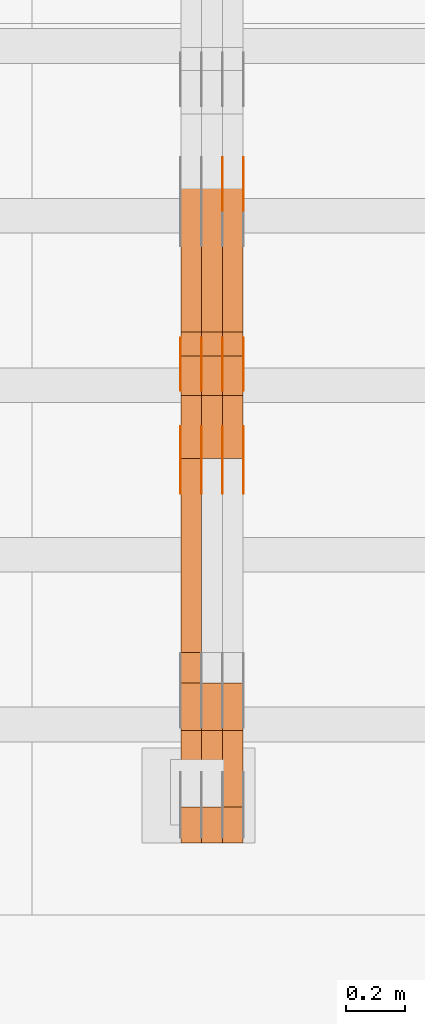
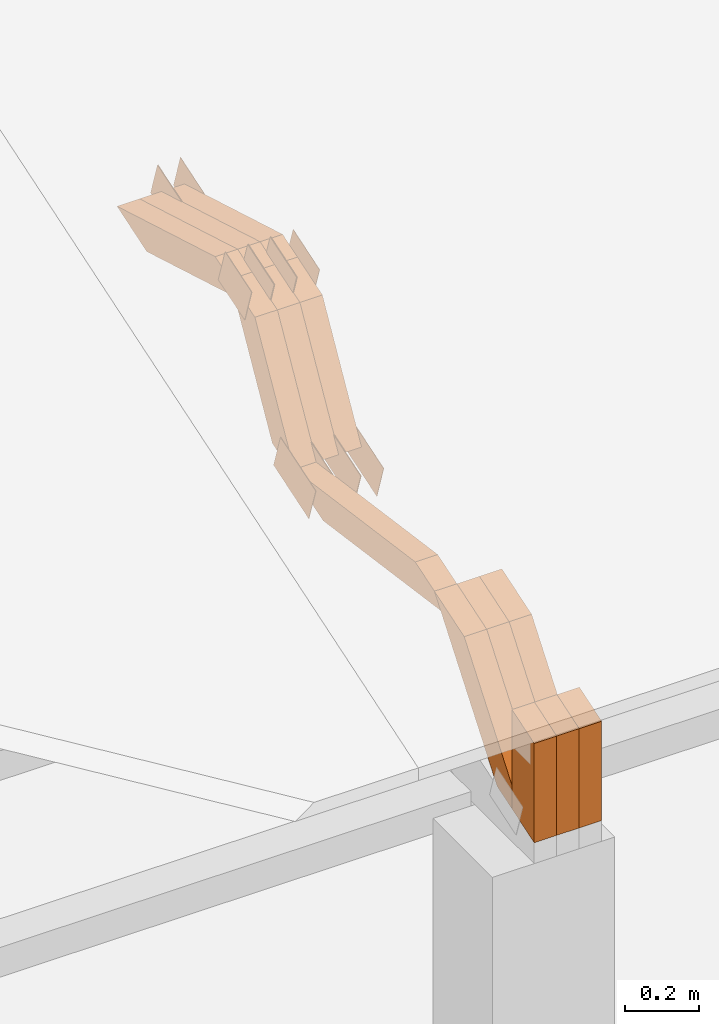
# One storey, part 112 of 385: 28 proxies.
"""IFC2X3 building model written with IfcOpenShell, lengths in millimetres."""

import ifcopenshell
import ifcopenshell.guid

model = None  # the IFC model being written
_history = None  # IfcOwnerHistory: only IFC2X3 demands one
_inside = {}  # id of a spatial element -> (the spatial element, [elements in it])
_under = {}  # id of a project, library or spatial element -> (it, [spatial elements below it])
_declared = {}  # id of a project -> (the project, [libraries it declares])
_typed = {}  # id of a type object -> (the type object, [elements of that type])
_made_of = {}  # id of a material, layer set ... -> (it, [elements and type objects made of it])


def new_model(schema):
    """Start an empty IFC model of exactly this schema.

    Asked for "IFC4X3", IfcOpenShell would pick the latest addendum, in which some entities
    have other attributes; the version numbers below select the first issue.
    IFC2X3 requires an IfcOwnerHistory on every rooted entity: one is made here for all.
    """
    global model, _history
    if schema == "IFC4X3":
        model = ifcopenshell.file(schema_version=(4, 3, 0, 0))
    else:
        model = ifcopenshell.file(schema=schema)
    _inside.clear()
    _under.clear()
    _declared.clear()
    _typed.clear()
    _made_of.clear()
    _history = None
    if model.schema == "IFC2X3":
        org = make("IfcOrganization", Name="unknown")
        user = make(
            "IfcPersonAndOrganization",
            ThePerson=make("IfcPerson", FamilyName="unknown"),
            TheOrganization=org,
        )
        app = make(
            "IfcApplication",
            ApplicationDeveloper=org,
            Version="unknown",
            ApplicationFullName="unknown",
            ApplicationIdentifier="unknown",
        )
        _history = make(
            "IfcOwnerHistory",
            OwningUser=user,
            OwningApplication=app,
            ChangeAction="ADDED",
            CreationDate=0,
        )
    return model


def make(cls, **values):
    """One entity of the class cls with the attributes given. An attribute that is None is left unset."""
    return model.create_entity(
        cls, **{name: value for name, value in values.items() if value is not None}
    )


def entity(cls, *values):
    """Any entity or typed value of the class cls, its attributes in the order of the schema. None: left unset."""
    e = model.create_entity(cls)
    for i, value in enumerate(values):
        if value is not None:
            e[i] = value
    return e


def rooted(cls, **values):
    """An entity with a GlobalId (a new one), such as an element, a storey or a relation."""
    return make(cls, GlobalId=ifcopenshell.guid.new(), OwnerHistory=_history, **values)


def si_unit(unit_type, name, prefix=None):
    """IfcSIUnit, for example si_unit("LENGTHUNIT", "METRE", prefix="MILLI")."""
    return make("IfcSIUnit", UnitType=unit_type, Prefix=prefix, Name=name)


def converted_unit(unit_type, name, factor, base, dimensions=None, offset=None):
    """IfcConversionBasedUnit, such as the inch: factor (a typed value) times the base unit."""
    return make(
        "IfcConversionBasedUnit"
        if offset is None
        else "IfcConversionBasedUnitWithOffset",
        ConversionOffset=offset,
        Dimensions=None
        if dimensions is None
        else entity("IfcDimensionalExponents", *dimensions),
        UnitType=unit_type,
        Name=name,
        ConversionFactor=make(
            "IfcMeasureWithUnit", ValueComponent=factor, UnitComponent=base
        ),
    )


def derived_unit(unit_type, elements):
    """IfcDerivedUnit: a product of units, each with its exponent."""
    return make(
        "IfcDerivedUnit",
        Elements=[
            make("IfcDerivedUnitElement", Unit=unit, Exponent=power)
            for unit, power in elements
        ],
        UnitType=unit_type,
    )


def assignment(units):
    """IfcUnitAssignment: the units of a project."""
    return None if units is None else make("IfcUnitAssignment", Units=units)


def point(xyz):
    """IfcCartesianPoint."""
    return None if xyz is None else make("IfcCartesianPoint", Coordinates=xyz)


def direction(xyz):
    """IfcDirection."""
    return None if xyz is None else make("IfcDirection", DirectionRatios=xyz)


def frame(location, z_axis=None, x_axis=None):
    """IfcAxis2Placement3D, a coordinate frame: its origin and axes. An axis left out is left unset."""
    return make(
        "IfcAxis2Placement3D",
        Location=point(location),
        Axis=direction(z_axis),
        RefDirection=direction(x_axis),
    )


def origin():
    """The frame at (0, 0, 0) with its axes left unset."""
    return frame((0.0, 0.0, 0.0))


def place(relative_to, where):
    """IfcLocalPlacement: puts the frame where relative to a parent placement (None: the world)."""
    return make(
        "IfcLocalPlacement", PlacementRelTo=relative_to, RelativePlacement=where
    )


def context(
    kind, dimensions, precision=None, world=None, true_north=None, identifier=None
):
    """IfcGeometricRepresentationContext, for example the 3D "Model" context."""
    return make(
        "IfcGeometricRepresentationContext",
        ContextIdentifier=identifier,
        ContextType=kind,
        CoordinateSpaceDimension=dimensions,
        Precision=precision,
        WorldCoordinateSystem=world,
        TrueNorth=true_north,
    )


def subcontext(parent, identifier, kind, view, scale=None):
    """IfcGeometricRepresentationSubContext, for example "Body" below "Model"."""
    return make(
        "IfcGeometricRepresentationSubContext",
        ContextIdentifier=identifier,
        ContextType=kind,
        ParentContext=parent,
        TargetScale=scale,
        TargetView=view,
    )


def project(units=None, contexts=None):
    """IfcProject with its units and contexts."""
    return rooted(
        "IfcProject",
        Name="project",
        RepresentationContexts=contexts,
        UnitsInContext=assignment(units),
    )


def spatial(cls, under=None, at=None, **own):
    """A site, building, storey or space (cls), placed at a placement, below another one or the project."""
    s = rooted(cls, ObjectPlacement=at, **own)
    if under is not None:
        _under.setdefault(under.id(), (under, []))[1].append(s)
    return s


def polyline(points):
    """IfcPolyline through the points."""
    return make("IfcPolyline", Points=[point(p) for p in points])


def outline(outer, holes=None, kind="AREA"):
    """IfcArbitraryClosedProfileDef: a profile drawn as a closed curve; with holes, ...WithVoids."""
    if holes is None:
        return make("IfcArbitraryClosedProfileDef", ProfileType=kind, OuterCurve=outer)
    return make(
        "IfcArbitraryProfileDefWithVoids",
        ProfileType=kind,
        OuterCurve=outer,
        InnerCurves=holes,
    )


def extrude(swept, where, along, depth):
    """IfcExtrudedAreaSolid: the profile swept, set in the frame where, extruded along a direction by depth."""
    return make(
        "IfcExtrudedAreaSolid",
        SweptArea=swept,
        Position=where,
        ExtrudedDirection=direction(along),
        Depth=depth,
    )


def shape(context_of_items, identifier, shape_type, items):
    """IfcShapeRepresentation: the items that make up one representation, for example the "Body"."""
    return make(
        "IfcShapeRepresentation",
        ContextOfItems=context_of_items,
        RepresentationIdentifier=identifier,
        RepresentationType=shape_type,
        Items=items,
    )


def source(mapping_origin, context_of_items, identifier, shape_type, items):
    """IfcRepresentationMap: a shape defined once, which mapped items show again and again."""
    return make(
        "IfcRepresentationMap",
        MappingOrigin=mapping_origin,
        MappedRepresentation=shape(context_of_items, identifier, shape_type, items),
    )


def transform(
    local_origin,
    x_axis=None,
    y_axis=None,
    z_axis=None,
    scale=None,
    scale2=None,
    scale3=None,
    uniform=True,
):
    """IfcCartesianTransformationOperator3D, or its non-uniform kind. x_axis, y_axis, z_axis: its Axis1, 2, 3."""
    if uniform:
        return make(
            "IfcCartesianTransformationOperator3D",
            Axis1=direction(x_axis),
            Axis2=direction(y_axis),
            LocalOrigin=point(local_origin),
            Scale=scale,
            Axis3=direction(z_axis),
        )
    return make(
        "IfcCartesianTransformationOperator3DnonUniform",
        Axis1=direction(x_axis),
        Axis2=direction(y_axis),
        LocalOrigin=point(local_origin),
        Scale=scale,
        Axis3=direction(z_axis),
        Scale2=scale2,
        Scale3=scale3,
    )


def mapped(mapping_source, mapping_target):
    """IfcMappedItem: shows the shape of a source again, moved by a transform."""
    return make(
        "IfcMappedItem", MappingSource=mapping_source, MappingTarget=mapping_target
    )


def material(Name=None, Category=None):
    """IfcMaterial."""
    return make("IfcMaterial", Name=Name, Category=Category)


def made_of(thing, what):
    """Note that an element or type object is made of a material, layer set ...; save() writes the relation."""
    if what is not None:
        _made_of.setdefault(what.id(), (what, []))[1].append(thing)
    return thing


def type_object(cls, material=None, **own):
    """A type object (cls), such as IfcWallType, which elements share."""
    return made_of(rooted(cls, **own), material)


def type_shapes(of_type, sources):
    """Give a type object the sources (RepresentationMaps) that its elements show as mapped items."""
    of_type.RepresentationMaps = sources


def element(
    cls,
    number,
    at=None,
    inside=None,
    cuts=None,
    type_object=None,
    material=None,
    context=None,
    identifier="Body",
    shape_type=None,
    held_by="IfcProductDefinitionShape",
    body=None,
    shapes=None,
    **own,
):
    """One element of the class cls, such as IfcWall. Its Tag is "e" and its number.

    at: its placement. inside: the storey or other place that contains it. cuts: it is an
    opening in that element (IfcRelVoidsElement). A single representation is given by context,
    identifier, shape_type and body (its items); several are given by shapes. held_by: the class
    of the entity that holds the representations. save() writes the other relations.
    """
    e = rooted(cls, Tag="e%d" % number, ObjectPlacement=at, **own)
    if body is not None:
        shapes = [shape(context, identifier, shape_type, body)]
    if shapes is not None:
        e.Representation = make(held_by, Representations=shapes)
    if inside is not None:
        _inside.setdefault(inside.id(), (inside, []))[1].append(e)
    if cuts is not None:
        rooted(
            "IfcRelVoidsElement", RelatingBuildingElement=cuts, RelatedOpeningElement=e
        )
    if type_object is not None:
        _typed.setdefault(type_object.id(), (type_object, []))[1].append(e)
    return made_of(e, material)


def aggregate(whole, parts):
    """IfcRelAggregates: a whole, such as a stair, and the parts it consists of."""
    return rooted("IfcRelAggregates", RelatingObject=whole, RelatedObjects=parts)


def save(model, path):
    """Write the relations noted so far, then the file.

    IfcRelAggregates (storeys below a building ...), IfcRelContainedInSpatialStructure (elements
    in a storey), IfcRelDefinesByType, IfcRelAssociatesMaterial and IfcRelDeclares: one each for
    every whole, place, type object, material and project.
    """
    for whole, parts in _under.values():
        aggregate(whole, parts)
    for where, things in _inside.values():
        rooted(
            "IfcRelContainedInSpatialStructure",
            RelatedElements=things,
            RelatingStructure=where,
        )
    for kind, things in _typed.values():
        rooted("IfcRelDefinesByType", RelatedObjects=things, RelatingType=kind)
    for what, things in _made_of.values():
        rooted("IfcRelAssociatesMaterial", RelatedObjects=things, RelatingMaterial=what)
    for by, libraries in _declared.values():
        rooted("IfcRelDeclares", RelatingContext=by, RelatedDefinitions=libraries)
    model.write(path)


model = new_model("IFC2X3")

# Units and contexts
model_context = context("Model", 3, precision=0.01, world=origin(), true_north=direction((6.12303176911189e-17, 1.0)))
body_context = subcontext(model_context, "Body", "Model", "MODEL_VIEW")
ifc_project = project(units=[si_unit("LENGTHUNIT", "METRE", prefix="MILLI"), si_unit("AREAUNIT", "SQUARE_METRE"), si_unit("VOLUMEUNIT", "CUBIC_METRE"), converted_unit("PLANEANGLEUNIT", "DEGREE", entity("IfcRatioMeasure", 0.0174532925199433), si_unit("PLANEANGLEUNIT", "RADIAN"), dimensions=[0, 0, 0, 0, 0, 0, 0]), si_unit("MASSUNIT", "GRAM", prefix="KILO"), derived_unit("MASSDENSITYUNIT", [(si_unit("MASSUNIT", "GRAM", prefix="KILO"), 1), (si_unit("LENGTHUNIT", "METRE"), -3)]), si_unit("TIMEUNIT", "SECOND"), si_unit("FREQUENCYUNIT", "HERTZ"), si_unit("THERMODYNAMICTEMPERATUREUNIT", "DEGREE_CELSIUS"), derived_unit("THERMALTRANSMITTANCEUNIT", [(si_unit("MASSUNIT", "GRAM", prefix="KILO"), 1), (si_unit("THERMODYNAMICTEMPERATUREUNIT", "KELVIN"), -1), (si_unit("TIMEUNIT", "SECOND"), -3)]), derived_unit("VOLUMETRICFLOWRATEUNIT", [(si_unit("LENGTHUNIT", "METRE"), 3), (si_unit("TIMEUNIT", "SECOND"), -1)]), si_unit("ELECTRICCURRENTUNIT", "AMPERE"), si_unit("ELECTRICVOLTAGEUNIT", "VOLT"), si_unit("POWERUNIT", "WATT"), si_unit("FORCEUNIT", "NEWTON", prefix="KILO"), si_unit("ILLUMINANCEUNIT", "LUX"), si_unit("LUMINOUSFLUXUNIT", "LUMEN"), si_unit("LUMINOUSINTENSITYUNIT", "CANDELA"), derived_unit("USERDEFINED", [(si_unit("MASSUNIT", "GRAM", prefix="KILO"), -1), (si_unit("LENGTHUNIT", "METRE"), -2), (si_unit("TIMEUNIT", "SECOND"), 3), (si_unit("LUMINOUSFLUXUNIT", "LUMEN"), 1)]), derived_unit("LINEARVELOCITYUNIT", [(si_unit("LENGTHUNIT", "METRE"), 1), (si_unit("TIMEUNIT", "SECOND"), -1)]), si_unit("PRESSUREUNIT", "PASCAL"), derived_unit("USERDEFINED", [(si_unit("LENGTHUNIT", "METRE"), -2), (si_unit("MASSUNIT", "GRAM", prefix="KILO"), 1), (si_unit("TIMEUNIT", "SECOND"), -2)])], contexts=[model_context])

# Site, building, storey
site_placement = place(None, origin())
site = spatial("IfcSite", under=ifc_project, at=site_placement, CompositionType="ELEMENT")
building_placement = place(site_placement, origin())
building = spatial("IfcBuilding", under=site, at=building_placement, CompositionType="ELEMENT")
storey_placement = place(building_placement, origin())
storey = spatial("IfcBuildingStorey", under=building, at=storey_placement, Name="Default", CompositionType="ELEMENT", Elevation=0.0)

# Proxies
ifc_material_1 = material(Name="IfcSurfaceStyle #270822")
building_element_proxy_type_1 = type_object("IfcBuildingElementProxyType", PredefinedType="NOTDEFINED", material=ifc_material_1)
shared_shape_1 = source(origin(), body_context, "Body", "SweptSolid", [
    extrude(outline(polyline([(-99.9998204243802, -60.000067376167), (99.9998338462265, -60.000067376167), (99.9998204243802, 60.000067376167), (-99.9998338462265, 60.000067376167), (-99.9998204243802, -60.000067376167)])), frame((100.000602015329, 60.0001864986889, 0.0), z_axis=(0.0, 0.0, 1.0), x_axis=(-1.0, 0.0, 0.0)), (0.0, 0.0, 1.0), 1.3),
])
type_shapes(building_element_proxy_type_1, [shared_shape_1])
proxy_1_placement = place(building_placement, frame((21386.3, 4114.85465165112, 513.097031388771), z_axis=(-1.0, 0.0, 0.0), x_axis=(0.0, 0.951056516295124, 0.309016994375039)))
element("IfcBuildingElementProxy", 1, at=proxy_1_placement, inside=storey, type_object=building_element_proxy_type_1, material=ifc_material_1, context=body_context, shape_type="MappedRepresentation", body=[
    mapped(shared_shape_1, transform((0.0, 0.0, 0.0), scale=1.0)),
])
ifc_material_2 = material(Name="IfcSurfaceStyle #270765")
building_element_proxy_type_2 = type_object("IfcBuildingElementProxyType", PredefinedType="NOTDEFINED", material=ifc_material_2)
shared_shape_2 = source(origin(), body_context, "Body", "SweptSolid", [
    extrude(outline(polyline([(-99.9998204243802, -60.000067376167), (99.9998338462265, -60.000067376167), (99.9998204243802, 60.000067376167), (-99.9998338462265, 60.000067376167), (-99.9998204243802, -60.000067376167)])), frame((100.000602015329, 60.0001864986889, 0.0), z_axis=(0.0, 0.0, 1.0), x_axis=(-1.0, 0.0, 0.0)), (0.0, 0.0, 1.0), 1.3),
])
type_shapes(building_element_proxy_type_2, [shared_shape_2])
proxy_2_placement = place(building_placement, frame((21315.0, 4114.85465165112, 513.097031388771), z_axis=(-1.0, 0.0, 0.0), x_axis=(0.0, 0.951056516295124, 0.309016994375039)))
element("IfcBuildingElementProxy", 2, at=proxy_2_placement, inside=storey, type_object=building_element_proxy_type_2, material=ifc_material_2, context=body_context, shape_type="MappedRepresentation", body=[
    mapped(shared_shape_2, transform((0.0, 0.0, 0.0), scale=1.0)),
])
ifc_material_3 = material(Name="IfcSurfaceStyle #270708")
building_element_proxy_type_3 = type_object("IfcBuildingElementProxyType", PredefinedType="NOTDEFINED", material=ifc_material_3)
shared_shape_3 = source(origin(), body_context, "Body", "SweptSolid", [
    extrude(outline(polyline([(-99.9998204243802, -60.000067376167), (99.9998338462265, -60.000067376167), (99.9998204243802, 60.000067376167), (-99.9998338462265, 60.000067376167), (-99.9998204243802, -60.000067376167)])), frame((100.000602015329, 60.0001864986889, 0.0), z_axis=(0.0, 0.0, 1.0), x_axis=(-1.0, 0.0, 0.0)), (0.0, 0.0, 1.0), 1.3),
])
type_shapes(building_element_proxy_type_3, [shared_shape_3])
proxy_3_placement = place(building_placement, frame((21316.3, 4114.85465165112, 513.097031388771), z_axis=(-1.0, 0.0, 0.0), x_axis=(0.0, 0.951056516295124, 0.309016994375039)))
element("IfcBuildingElementProxy", 3, at=proxy_3_placement, inside=storey, type_object=building_element_proxy_type_3, material=ifc_material_3, context=body_context, shape_type="MappedRepresentation", body=[
    mapped(shared_shape_3, transform((0.0, 0.0, 0.0), scale=1.0)),
])
ifc_material_4 = material(Name="IfcSurfaceStyle #270651")
building_element_proxy_type_4 = type_object("IfcBuildingElementProxyType", PredefinedType="NOTDEFINED", material=ifc_material_4)
shared_shape_4 = source(origin(), body_context, "Body", "SweptSolid", [
    extrude(outline(polyline([(-99.9998204243802, -60.000067376167), (99.9998338462265, -60.000067376167), (99.9998204243802, 60.000067376167), (-99.9998338462265, 60.000067376167), (-99.9998204243802, -60.000067376167)])), frame((100.000602015329, 60.0001864986889, 0.0), z_axis=(0.0, 0.0, 1.0), x_axis=(-1.0, 0.0, 0.0)), (0.0, 0.0, 1.0), 1.29999999999998),
])
type_shapes(building_element_proxy_type_4, [shared_shape_4])
proxy_4_placement = place(building_placement, frame((21245.0, 4114.85465165112, 513.097031388771), z_axis=(-1.0, 0.0, 0.0), x_axis=(0.0, 0.951056516295124, 0.309016994375039)))
element("IfcBuildingElementProxy", 4, at=proxy_4_placement, inside=storey, type_object=building_element_proxy_type_4, material=ifc_material_4, context=body_context, shape_type="MappedRepresentation", body=[
    mapped(shared_shape_4, transform((0.0, 0.0, 0.0), scale=1.0)),
])
ifc_material_5 = material(Name="IfcSurfaceStyle #270594")
building_element_proxy_type_5 = type_object("IfcBuildingElementProxyType", PredefinedType="NOTDEFINED", material=ifc_material_5)
shared_shape_5 = source(origin(), body_context, "Body", "SweptSolid", [
    extrude(outline(polyline([(-99.9998204243802, -60.000067376167), (99.9998338462265, -60.000067376167), (99.9998204243802, 60.000067376167), (-99.9998338462265, 60.000067376167), (-99.9998204243802, -60.000067376167)])), frame((100.000602015329, 60.0001864986889, 0.0), z_axis=(0.0, 0.0, 1.0), x_axis=(-1.0, 0.0, 0.0)), (0.0, 0.0, 1.0), 1.29999999999998),
])
type_shapes(building_element_proxy_type_5, [shared_shape_5])
proxy_5_placement = place(building_placement, frame((21246.3, 4114.85465165112, 513.097031388771), z_axis=(-1.0, 0.0, 0.0), x_axis=(0.0, 0.951056516295124, 0.309016994375039)))
element("IfcBuildingElementProxy", 5, at=proxy_5_placement, inside=storey, type_object=building_element_proxy_type_5, material=ifc_material_5, context=body_context, shape_type="MappedRepresentation", body=[
    mapped(shared_shape_5, transform((0.0, 0.0, 0.0), scale=1.0)),
])
ifc_material_6 = material(Name="IfcSurfaceStyle #270537")
building_element_proxy_type_6 = type_object("IfcBuildingElementProxyType", PredefinedType="NOTDEFINED", material=ifc_material_6)
shared_shape_6 = source(origin(), body_context, "Body", "SweptSolid", [
    extrude(outline(polyline([(-99.9998204243802, -60.000067376167), (99.9998338462265, -60.000067376167), (99.9998204243802, 60.000067376167), (-99.9998338462265, 60.000067376167), (-99.9998204243802, -60.000067376167)])), frame((100.000602015329, 60.0001864986889, 0.0), z_axis=(0.0, 0.0, 1.0), x_axis=(-1.0, 0.0, 0.0)), (0.0, 0.0, 1.0), 1.29999999999999),
])
type_shapes(building_element_proxy_type_6, [shared_shape_6])
proxy_6_placement = place(building_placement, frame((21175.0, 4114.85465165112, 513.097031388771), z_axis=(-1.0, 0.0, 0.0), x_axis=(0.0, 0.951056516295124, 0.309016994375039)))
element("IfcBuildingElementProxy", 6, at=proxy_6_placement, inside=storey, type_object=building_element_proxy_type_6, material=ifc_material_6, context=body_context, shape_type="MappedRepresentation", body=[
    mapped(shared_shape_6, transform((0.0, 0.0, 0.0), scale=1.0)),
])
ifc_material_7 = material(Name="IfcSurfaceStyle #270480")
building_element_proxy_type_7 = type_object("IfcBuildingElementProxyType", PredefinedType="NOTDEFINED", material=ifc_material_7)
shared_shape_7 = source(origin(), body_context, "Body", "SweptSolid", [
    extrude(outline(polyline([(-74.9998707133927, -60.0000596852269), (74.9998841352353, -60.0000596852269), (74.999861282944, 60.0000596852269), (-74.9998747047866, 60.0000596852269), (-74.9998707133927, -60.0000596852269)])), frame((74.9998841352353, 60.0000596852269, 0.0), z_axis=(0.0, 0.0, 1.0), x_axis=(-1.0, 0.0, 0.0)), (0.0, 0.0, 1.0), 1.3),
])
type_shapes(building_element_proxy_type_7, [shared_shape_7])
proxy_7_placement = place(building_placement, frame((21386.3, 5067.4882362875, 826.131473120182), z_axis=(-1.0, 0.0, 0.0), x_axis=(0.0, 0.951056516295124, 0.309016994375039)))
element("IfcBuildingElementProxy", 7, at=proxy_7_placement, inside=storey, type_object=building_element_proxy_type_7, material=ifc_material_7, context=body_context, shape_type="MappedRepresentation", body=[
    mapped(shared_shape_7, transform((0.0, 0.0, 0.0), scale=1.0)),
])
ifc_material_8 = material(Name="IfcSurfaceStyle #270423")
building_element_proxy_type_8 = type_object("IfcBuildingElementProxyType", PredefinedType="NOTDEFINED", material=ifc_material_8)
shared_shape_8 = source(origin(), body_context, "Body", "SweptSolid", [
    extrude(outline(polyline([(-74.9998707133927, -60.0000596852269), (74.9998841352353, -60.0000596852269), (74.999861282944, 60.0000596852269), (-74.9998747047866, 60.0000596852269), (-74.9998707133927, -60.0000596852269)])), frame((74.9998841352353, 60.0000596852269, 0.0), z_axis=(0.0, 0.0, 1.0), x_axis=(-1.0, 0.0, 0.0)), (0.0, 0.0, 1.0), 1.3),
])
type_shapes(building_element_proxy_type_8, [shared_shape_8])
proxy_8_placement = place(building_placement, frame((21315.0, 5067.4882362875, 826.131473120182), z_axis=(-1.0, 0.0, 0.0), x_axis=(0.0, 0.951056516295124, 0.309016994375039)))
element("IfcBuildingElementProxy", 8, at=proxy_8_placement, inside=storey, type_object=building_element_proxy_type_8, material=ifc_material_8, context=body_context, shape_type="MappedRepresentation", body=[
    mapped(shared_shape_8, transform((0.0, 0.0, 0.0), scale=1.0)),
])
ifc_material_9 = material(Name="IfcSurfaceStyle #270366")
building_element_proxy_type_9 = type_object("IfcBuildingElementProxyType", PredefinedType="NOTDEFINED", material=ifc_material_9)
shared_shape_9 = source(origin(), body_context, "Body", "SweptSolid", [
    extrude(outline(polyline([(-74.9998707133927, -60.0000596852269), (74.9998841352353, -60.0000596852269), (74.999861282944, 60.0000596852269), (-74.9998747047866, 60.0000596852269), (-74.9998707133927, -60.0000596852269)])), frame((74.9998841352353, 60.0000596852269, 0.0), z_axis=(0.0, 0.0, 1.0), x_axis=(-1.0, 0.0, 0.0)), (0.0, 0.0, 1.0), 1.3),
])
type_shapes(building_element_proxy_type_9, [shared_shape_9])
proxy_9_placement = place(building_placement, frame((21316.3, 5067.4882362875, 826.131473120182), z_axis=(-1.0, 0.0, 0.0), x_axis=(0.0, 0.951056516295124, 0.309016994375039)))
element("IfcBuildingElementProxy", 9, at=proxy_9_placement, inside=storey, type_object=building_element_proxy_type_9, material=ifc_material_9, context=body_context, shape_type="MappedRepresentation", body=[
    mapped(shared_shape_9, transform((0.0, 0.0, 0.0), scale=1.0)),
])
ifc_material_10 = material(Name="IfcSurfaceStyle #263640")
building_element_proxy_type_10 = type_object("IfcBuildingElementProxyType", PredefinedType="NOTDEFINED", material=ifc_material_10)
shared_shape_10 = source(origin(), body_context, "Body", "SweptSolid", [
    extrude(outline(polyline([(-74.999865998172, -60.0000306612919), (74.999869989555, -60.0000306612919), (74.999865998172, 60.0000306612919), (-74.999869989555, 60.0000306612919), (-74.999865998172, -60.0000306612919)])), frame((75.0006726017528, 60.0001996460842, 0.0), z_axis=(0.0, 0.0, 1.0), x_axis=(-1.0, 0.0, 0.0)), (0.0, 0.0, 1.0), 1.3),
])
type_shapes(building_element_proxy_type_10, [shared_shape_10])
proxy_10_placement = place(building_placement, frame((21386.3, 4460.38978242656, 957.314497110567), z_axis=(-1.0, 0.0, 0.0), x_axis=(0.0, 0.951056516295154, 0.309016994374948)))
element("IfcBuildingElementProxy", 10, at=proxy_10_placement, inside=storey, type_object=building_element_proxy_type_10, material=ifc_material_10, context=body_context, shape_type="MappedRepresentation", body=[
    mapped(shared_shape_10, transform((0.0, 0.0, 0.0), scale=1.0)),
])
ifc_material_11 = material(Name="IfcSurfaceStyle #263583")
building_element_proxy_type_11 = type_object("IfcBuildingElementProxyType", PredefinedType="NOTDEFINED", material=ifc_material_11)
shared_shape_11 = source(origin(), body_context, "Body", "SweptSolid", [
    extrude(outline(polyline([(-74.999865998172, -60.0000306612919), (74.999869989555, -60.0000306612919), (74.999865998172, 60.0000306612919), (-74.999869989555, 60.0000306612919), (-74.999865998172, -60.0000306612919)])), frame((75.0006726017528, 60.0001996460842, 0.0), z_axis=(0.0, 0.0, 1.0), x_axis=(-1.0, 0.0, 0.0)), (0.0, 0.0, 1.0), 1.3),
])
type_shapes(building_element_proxy_type_11, [shared_shape_11])
proxy_11_placement = place(building_placement, frame((21315.0, 4460.38978242656, 957.314497110567), z_axis=(-1.0, 0.0, 0.0), x_axis=(0.0, 0.951056516295154, 0.309016994374948)))
element("IfcBuildingElementProxy", 11, at=proxy_11_placement, inside=storey, type_object=building_element_proxy_type_11, material=ifc_material_11, context=body_context, shape_type="MappedRepresentation", body=[
    mapped(shared_shape_11, transform((0.0, 0.0, 0.0), scale=1.0)),
])
ifc_material_12 = material(Name="IfcSurfaceStyle #263526")
building_element_proxy_type_12 = type_object("IfcBuildingElementProxyType", PredefinedType="NOTDEFINED", material=ifc_material_12)
shared_shape_12 = source(origin(), body_context, "Body", "SweptSolid", [
    extrude(outline(polyline([(-74.999865998172, -60.0000306612919), (74.999869989555, -60.0000306612919), (74.999865998172, 60.0000306612919), (-74.999869989555, 60.0000306612919), (-74.999865998172, -60.0000306612919)])), frame((75.0006726017528, 60.0001996460842, 0.0), z_axis=(0.0, 0.0, 1.0), x_axis=(-1.0, 0.0, 0.0)), (0.0, 0.0, 1.0), 1.3),
])
type_shapes(building_element_proxy_type_12, [shared_shape_12])
proxy_12_placement = place(building_placement, frame((21316.3, 4460.38978242656, 957.314497110567), z_axis=(-1.0, 0.0, 0.0), x_axis=(0.0, 0.951056516295154, 0.309016994374948)))
element("IfcBuildingElementProxy", 12, at=proxy_12_placement, inside=storey, type_object=building_element_proxy_type_12, material=ifc_material_12, context=body_context, shape_type="MappedRepresentation", body=[
    mapped(shared_shape_12, transform((0.0, 0.0, 0.0), scale=1.0)),
])
ifc_material_13 = material(Name="IfcSurfaceStyle #263469")
building_element_proxy_type_13 = type_object("IfcBuildingElementProxyType", PredefinedType="NOTDEFINED", material=ifc_material_13)
shared_shape_13 = source(origin(), body_context, "Body", "SweptSolid", [
    extrude(outline(polyline([(-74.999865998172, -60.0000306612919), (74.999869989555, -60.0000306612919), (74.999865998172, 60.0000306612919), (-74.999869989555, 60.0000306612919), (-74.999865998172, -60.0000306612919)])), frame((75.0006726017528, 60.0001996460842, 0.0), z_axis=(0.0, 0.0, 1.0), x_axis=(-1.0, 0.0, 0.0)), (0.0, 0.0, 1.0), 1.29999999999999),
])
type_shapes(building_element_proxy_type_13, [shared_shape_13])
proxy_13_placement = place(building_placement, frame((21245.0, 4460.38978242656, 957.314497110567), z_axis=(-1.0, 0.0, 0.0), x_axis=(0.0, 0.951056516295154, 0.309016994374948)))
element("IfcBuildingElementProxy", 13, at=proxy_13_placement, inside=storey, type_object=building_element_proxy_type_13, material=ifc_material_13, context=body_context, shape_type="MappedRepresentation", body=[
    mapped(shared_shape_13, transform((0.0, 0.0, 0.0), scale=1.0)),
])
ifc_material_14 = material(Name="IfcSurfaceStyle #263412")
building_element_proxy_type_14 = type_object("IfcBuildingElementProxyType", PredefinedType="NOTDEFINED", material=ifc_material_14)
shared_shape_14 = source(origin(), body_context, "Body", "SweptSolid", [
    extrude(outline(polyline([(-74.999865998172, -60.0000306612919), (74.999869989555, -60.0000306612919), (74.999865998172, 60.0000306612919), (-74.999869989555, 60.0000306612919), (-74.999865998172, -60.0000306612919)])), frame((75.0006726017528, 60.0001996460842, 0.0), z_axis=(0.0, 0.0, 1.0), x_axis=(-1.0, 0.0, 0.0)), (0.0, 0.0, 1.0), 1.29999999999999),
])
type_shapes(building_element_proxy_type_14, [shared_shape_14])
proxy_14_placement = place(building_placement, frame((21246.3, 4460.38978242656, 957.314497110567), z_axis=(-1.0, 0.0, 0.0), x_axis=(0.0, 0.951056516295154, 0.309016994374948)))
element("IfcBuildingElementProxy", 14, at=proxy_14_placement, inside=storey, type_object=building_element_proxy_type_14, material=ifc_material_14, context=body_context, shape_type="MappedRepresentation", body=[
    mapped(shared_shape_14, transform((0.0, 0.0, 0.0), scale=1.0)),
])
ifc_material_15 = material(Name="IfcSurfaceStyle #263355")
building_element_proxy_type_15 = type_object("IfcBuildingElementProxyType", PredefinedType="NOTDEFINED", material=ifc_material_15)
shared_shape_15 = source(origin(), body_context, "Body", "SweptSolid", [
    extrude(outline(polyline([(-74.999865998172, -60.0000306612919), (74.999869989555, -60.0000306612919), (74.999865998172, 60.0000306612919), (-74.999869989555, 60.0000306612919), (-74.999865998172, -60.0000306612919)])), frame((75.0006726017528, 60.0001996460842, 0.0), z_axis=(0.0, 0.0, 1.0), x_axis=(-1.0, 0.0, 0.0)), (0.0, 0.0, 1.0), 1.29999999999999),
])
type_shapes(building_element_proxy_type_15, [shared_shape_15])
proxy_15_placement = place(building_placement, frame((21175.0, 4460.38978242656, 957.314497110567), z_axis=(-1.0, 0.0, 0.0), x_axis=(0.0, 0.951056516295154, 0.309016994374948)))
element("IfcBuildingElementProxy", 15, at=proxy_15_placement, inside=storey, type_object=building_element_proxy_type_15, material=ifc_material_15, context=body_context, shape_type="MappedRepresentation", body=[
    mapped(shared_shape_15, transform((0.0, 0.0, 0.0), scale=1.0)),
])
ifc_material_16 = material(Name="IfcSurfaceStyle #251112")
building_element_proxy_type_16 = type_object("IfcBuildingElementProxyType", Name="T1-W12 251110", PredefinedType="NOTDEFINED", material=ifc_material_16)
shared_shape_16 = source(origin(), body_context, "Body", "SweptSolid", [
    extrude(outline(polyline([(-249.405625983165, -47.5001691155616), (243.345753908996, -47.5001691155616), (232.115534842595, 2.39993474701938e-05), (162.527010966644, 47.5001571158879), (-388.58267373507, 47.5001571158879), (-249.405625983165, -47.5001691155616)])), frame((243.345867653852, 47.5001571158879, 0.0), z_axis=(0.0, 0.0, 1.0), x_axis=(-1.0, 0.0, 0.0)), (0.0, 0.0, 1.0), 70.0),
])
type_shapes(building_element_proxy_type_16, [shared_shape_16])
proxy_16_placement = place(building_placement, frame((21385.0, 4581.32698473631, 976.172276753357), z_axis=(-1.0, 0.0, 0.0), x_axis=(0.0, 0.959722067881787, -0.280951156645966)))
element("IfcBuildingElementProxy", 16, at=proxy_16_placement, inside=storey, type_object=building_element_proxy_type_16, material=ifc_material_16, Name="T1-W12", context=body_context, shape_type="MappedRepresentation", body=[
    mapped(shared_shape_16, transform((0.0, 0.0, 0.0), scale=1.0)),
])
ifc_material_17 = material(Name="IfcSurfaceStyle #251046")
building_element_proxy_type_17 = type_object("IfcBuildingElementProxyType", Name="T1-W12 251044", PredefinedType="NOTDEFINED", material=ifc_material_17)
shared_shape_17 = source(origin(), body_context, "Body", "SweptSolid", [
    extrude(outline(polyline([(-249.405625983165, -47.5001691155616), (243.345753908996, -47.5001691155616), (232.115534842595, 2.39993474701938e-05), (162.527010966644, 47.5001571158879), (-388.58267373507, 47.5001571158879), (-249.405625983165, -47.5001691155616)])), frame((243.345867653852, 47.5001571158879, 0.0), z_axis=(0.0, 0.0, 1.0), x_axis=(-1.0, 0.0, 0.0)), (0.0, 0.0, 1.0), 70.0),
])
type_shapes(building_element_proxy_type_17, [shared_shape_17])
proxy_17_placement = place(building_placement, frame((21315.0, 4581.32698473631, 976.172276753357), z_axis=(-1.0, 0.0, 0.0), x_axis=(0.0, 0.959722067881787, -0.280951156645966)))
element("IfcBuildingElementProxy", 17, at=proxy_17_placement, inside=storey, type_object=building_element_proxy_type_17, material=ifc_material_17, Name="T1-W12", context=body_context, shape_type="MappedRepresentation", body=[
    mapped(shared_shape_17, transform((0.0, 0.0, 0.0), scale=1.0)),
])
ifc_material_18 = material(Name="IfcSurfaceStyle #250980")
building_element_proxy_type_18 = type_object("IfcBuildingElementProxyType", Name="T1-W12 250978", PredefinedType="NOTDEFINED", material=ifc_material_18)
shared_shape_18 = source(origin(), body_context, "Body", "SweptSolid", [
    extrude(outline(polyline([(-249.405625983165, -47.5001691155616), (243.345753908996, -47.5001691155616), (232.115534842595, 2.39993474701938e-05), (162.527010966644, 47.5001571158879), (-388.58267373507, 47.5001571158879), (-249.405625983165, -47.5001691155616)])), frame((243.345867653852, 47.5001571158879, 0.0), z_axis=(0.0, 0.0, 1.0), x_axis=(-1.0, 0.0, 0.0)), (0.0, 0.0, 1.0), 70.0),
])
type_shapes(building_element_proxy_type_18, [shared_shape_18])
proxy_18_placement = place(building_placement, frame((21245.0, 4581.32698473631, 976.172276753357), z_axis=(-1.0, 0.0, 0.0), x_axis=(0.0, 0.959722067881787, -0.280951156645966)))
element("IfcBuildingElementProxy", 18, at=proxy_18_placement, inside=storey, type_object=building_element_proxy_type_18, material=ifc_material_18, Name="T1-W12", context=body_context, shape_type="MappedRepresentation", body=[
    mapped(shared_shape_18, transform((0.0, 0.0, 0.0), scale=1.0)),
])
ifc_material_19 = material(Name="IfcSurfaceStyle #250716")
building_element_proxy_type_19 = type_object("IfcBuildingElementProxyType", Name="T1-W27 250714", PredefinedType="NOTDEFINED", material=ifc_material_19)
shared_shape_19 = source(origin(), body_context, "Body", "SweptSolid", [
    extrude(outline(polyline([(-321.979763159708, -47.49993999164), (138.960018341432, -47.49993999164), (191.013775341887, -0.000473170132329126), (209.87827169492, 47.5001765767061), (-217.872302218531, 47.5001765767062), (-321.979763159708, -47.49993999164)])), frame((209.87827169492, 47.5001765767061, 0.0), z_axis=(0.0, 0.0, 1.0), x_axis=(-1.0, 0.0, 0.0)), (0.0, 0.0, 1.0), 70.0),
])
type_shapes(building_element_proxy_type_19, [shared_shape_19])
proxy_19_placement = place(building_placement, frame((21385.0, 4233.3125, 512.021728515625), z_axis=(-1.0, 0.0, 0.0), x_axis=(0.0, 0.494231057369727, 0.869330582650352)))
element("IfcBuildingElementProxy", 19, at=proxy_19_placement, inside=storey, type_object=building_element_proxy_type_19, material=ifc_material_19, Name="T1-W27", context=body_context, shape_type="MappedRepresentation", body=[
    mapped(shared_shape_19, transform((0.0, 0.0, 0.0), scale=1.0)),
])
ifc_material_20 = material(Name="IfcSurfaceStyle #250650")
building_element_proxy_type_20 = type_object("IfcBuildingElementProxyType", Name="T1-W27 250648", PredefinedType="NOTDEFINED", material=ifc_material_20)
shared_shape_20 = source(origin(), body_context, "Body", "SweptSolid", [
    extrude(outline(polyline([(-321.979763159708, -47.49993999164), (138.960018341432, -47.49993999164), (191.013775341887, -0.000473170132329126), (209.87827169492, 47.5001765767061), (-217.872302218531, 47.5001765767062), (-321.979763159708, -47.49993999164)])), frame((209.87827169492, 47.5001765767061, 0.0), z_axis=(0.0, 0.0, 1.0), x_axis=(-1.0, 0.0, 0.0)), (0.0, 0.0, 1.0), 70.0),
])
type_shapes(building_element_proxy_type_20, [shared_shape_20])
proxy_20_placement = place(building_placement, frame((21315.0, 4233.3125, 512.021728515625), z_axis=(-1.0, 0.0, 0.0), x_axis=(0.0, 0.494231057369727, 0.869330582650352)))
element("IfcBuildingElementProxy", 20, at=proxy_20_placement, inside=storey, type_object=building_element_proxy_type_20, material=ifc_material_20, Name="T1-W27", context=body_context, shape_type="MappedRepresentation", body=[
    mapped(shared_shape_20, transform((0.0, 0.0, 0.0), scale=1.0)),
])
ifc_material_21 = material(Name="IfcSurfaceStyle #250584")
building_element_proxy_type_21 = type_object("IfcBuildingElementProxyType", Name="T1-W27 250582", PredefinedType="NOTDEFINED", material=ifc_material_21)
shared_shape_21 = source(origin(), body_context, "Body", "SweptSolid", [
    extrude(outline(polyline([(-321.979763159708, -47.49993999164), (138.960018341432, -47.49993999164), (191.013775341887, -0.000473170132329126), (209.87827169492, 47.5001765767061), (-217.872302218531, 47.5001765767062), (-321.979763159708, -47.49993999164)])), frame((209.87827169492, 47.5001765767061, 0.0), z_axis=(0.0, 0.0, 1.0), x_axis=(-1.0, 0.0, 0.0)), (0.0, 0.0, 1.0), 70.0),
])
type_shapes(building_element_proxy_type_21, [shared_shape_21])
proxy_21_placement = place(building_placement, frame((21245.0, 4233.3125, 512.021728515625), z_axis=(-1.0, 0.0, 0.0), x_axis=(0.0, 0.494231057369727, 0.869330582650352)))
element("IfcBuildingElementProxy", 21, at=proxy_21_placement, inside=storey, type_object=building_element_proxy_type_21, material=ifc_material_21, Name="T1-W27", context=body_context, shape_type="MappedRepresentation", body=[
    mapped(shared_shape_21, transform((0.0, 0.0, 0.0), scale=1.0)),
])
ifc_material_22 = material(Name="IfcSurfaceStyle #250188")
building_element_proxy_type_22 = type_object("IfcBuildingElementProxyType", Name="T1-W3 250186", PredefinedType="NOTDEFINED", material=ifc_material_22)
shared_shape_22 = source(origin(), body_context, "Body", "SweptSolid", [
    extrude(outline(polyline([(-314.232579911788, -47.5000200125938), (325.164873061766, -47.5000200125938), (297.999869081008, 6.48085173424295e-05), (200.434027234171, 47.4999876083351), (-509.366189465157, 47.4999876083352), (-314.232579911788, -47.5000200125938)])), frame((325.164873061766, 47.5001564752191, 0.0), z_axis=(0.0, 0.0, 1.0), x_axis=(-1.0, 0.0, 0.0)), (0.0, 0.0, 1.0), 70.0),
])
type_shapes(building_element_proxy_type_22, [shared_shape_22])
proxy_22_placement = place(building_placement, frame((21245.0, 3457.43747924875, 620.49890325051), z_axis=(-1.0, 0.0, 0.0), x_axis=(0.0, 0.990367219823621, -0.138465771578512)))
element("IfcBuildingElementProxy", 22, at=proxy_22_placement, inside=storey, type_object=building_element_proxy_type_22, material=ifc_material_22, Name="T1-W3", context=body_context, shape_type="MappedRepresentation", body=[
    mapped(shared_shape_22, transform((0.0, 0.0, 0.0), scale=1.0)),
])
ifc_material_23 = material(Name="IfcSurfaceStyle #249924")
building_element_proxy_type_23 = type_object("IfcBuildingElementProxyType", Name="T1-W14 249922", PredefinedType="NOTDEFINED", material=ifc_material_23)
shared_shape_23 = source(origin(), body_context, "Body", "SweptSolid", [
    extrude(outline(polyline([(-374.484689776928, -47.499919737532), (177.199556189275, -47.499919737532), (246.893257937645, -5.36774925340877e-05), (185.487930694801, 47.4999465762783), (-235.096055044793, 47.4999465762784), (-374.484689776928, -47.499919737532)])), frame((246.893257937645, 47.5000959779252, 0.0), z_axis=(0.0, 0.0, 1.0), x_axis=(-1.0, 0.0, 0.0)), (0.0, 0.0, 1.0), 70.0),
])
type_shapes(building_element_proxy_type_23, [shared_shape_23])
proxy_23_placement = place(building_placement, frame((21385.0, 3022.42877773024, 136.329406512195), z_axis=(-1.0, 0.0, 0.0), x_axis=(0.0, 0.611854146609475, 0.790970608352037)))
element("IfcBuildingElementProxy", 23, at=proxy_23_placement, inside=storey, type_object=building_element_proxy_type_23, material=ifc_material_23, Name="T1-W14", context=body_context, shape_type="MappedRepresentation", body=[
    mapped(shared_shape_23, transform((0.0, 0.0, 0.0), scale=1.0)),
])
ifc_material_24 = material(Name="IfcSurfaceStyle #249858")
building_element_proxy_type_24 = type_object("IfcBuildingElementProxyType", Name="T1-W14 249856", PredefinedType="NOTDEFINED", material=ifc_material_24)
shared_shape_24 = source(origin(), body_context, "Body", "SweptSolid", [
    extrude(outline(polyline([(-374.484689776928, -47.499919737532), (177.199556189275, -47.499919737532), (246.893257937645, -5.36774925340877e-05), (185.487930694801, 47.4999465762783), (-235.096055044793, 47.4999465762784), (-374.484689776928, -47.499919737532)])), frame((246.893257937645, 47.5000959779252, 0.0), z_axis=(0.0, 0.0, 1.0), x_axis=(-1.0, 0.0, 0.0)), (0.0, 0.0, 1.0), 70.0),
])
type_shapes(building_element_proxy_type_24, [shared_shape_24])
proxy_24_placement = place(building_placement, frame((21315.0, 3022.42877773024, 136.329406512195), z_axis=(-1.0, 0.0, 0.0), x_axis=(0.0, 0.611854146609475, 0.790970608352037)))
element("IfcBuildingElementProxy", 24, at=proxy_24_placement, inside=storey, type_object=building_element_proxy_type_24, material=ifc_material_24, Name="T1-W14", context=body_context, shape_type="MappedRepresentation", body=[
    mapped(shared_shape_24, transform((0.0, 0.0, 0.0), scale=1.0)),
])
ifc_material_25 = material(Name="IfcSurfaceStyle #249792")
building_element_proxy_type_25 = type_object("IfcBuildingElementProxyType", Name="T1-W14 249790", PredefinedType="NOTDEFINED", material=ifc_material_25)
shared_shape_25 = source(origin(), body_context, "Body", "SweptSolid", [
    extrude(outline(polyline([(-374.484689776928, -47.499919737532), (177.199556189275, -47.499919737532), (246.893257937645, -5.36774925340877e-05), (185.487930694801, 47.4999465762783), (-235.096055044793, 47.4999465762784), (-374.484689776928, -47.499919737532)])), frame((246.893257937645, 47.5000959779252, 0.0), z_axis=(0.0, 0.0, 1.0), x_axis=(-1.0, 0.0, 0.0)), (0.0, 0.0, 1.0), 70.0),
])
type_shapes(building_element_proxy_type_25, [shared_shape_25])
proxy_25_placement = place(building_placement, frame((21245.0, 3022.42877773024, 136.329406512195), z_axis=(-1.0, 0.0, 0.0), x_axis=(0.0, 0.611854146609475, 0.790970608352037)))
element("IfcBuildingElementProxy", 25, at=proxy_25_placement, inside=storey, type_object=building_element_proxy_type_25, material=ifc_material_25, Name="T1-W14", context=body_context, shape_type="MappedRepresentation", body=[
    mapped(shared_shape_25, transform((0.0, 0.0, 0.0), scale=1.0)),
])
ifc_material_26 = material(Name="IfcSurfaceStyle #249726")
building_element_proxy_type_26 = type_object("IfcBuildingElementProxyType", Name="T1-E3 249724", PredefinedType="NOTDEFINED", material=ifc_material_26)
shared_shape_26 = source(origin(), body_context, "Body", "SweptSolid", [
    extrude(outline(polyline([(-182.839673995971, -60.0), (143.849313735962, -60.0), (182.839677810669, 60.0), (-143.84931755066, 60.0), (-182.839673995971, -60.0)])), frame((182.839677810669, 60.0, 0.0), z_axis=(0.0, 0.0, 1.0), x_axis=(-1.0, 0.0, 0.0)), (0.0, 0.0, 1.0), 70.0),
])
type_shapes(building_element_proxy_type_26, [shared_shape_26])
proxy_26_placement = place(building_placement, frame((21385.0, 2940.0, 68.27587890625), z_axis=(-1.0, 0.0, 0.0), x_axis=(0.0, 0.0, 1.0)))
element("IfcBuildingElementProxy", 26, at=proxy_26_placement, inside=storey, type_object=building_element_proxy_type_26, material=ifc_material_26, Name="T1-E3", context=body_context, shape_type="MappedRepresentation", body=[
    mapped(shared_shape_26, transform((0.0, 0.0, 0.0), scale=1.0)),
])
ifc_material_27 = material(Name="IfcSurfaceStyle #249669")
building_element_proxy_type_27 = type_object("IfcBuildingElementProxyType", Name="T1-E3 249667", PredefinedType="NOTDEFINED", material=ifc_material_27)
shared_shape_27 = source(origin(), body_context, "Body", "SweptSolid", [
    extrude(outline(polyline([(-182.839673995971, -60.0), (143.849313735962, -60.0), (182.839677810669, 60.0), (-143.84931755066, 60.0), (-182.839673995971, -60.0)])), frame((182.839677810669, 60.0, 0.0), z_axis=(0.0, 0.0, 1.0), x_axis=(-1.0, 0.0, 0.0)), (0.0, 0.0, 1.0), 70.0),
])
type_shapes(building_element_proxy_type_27, [shared_shape_27])
proxy_27_placement = place(building_placement, frame((21315.0, 2940.0, 68.27587890625), z_axis=(-1.0, 0.0, 0.0), x_axis=(0.0, 0.0, 1.0)))
element("IfcBuildingElementProxy", 27, at=proxy_27_placement, inside=storey, type_object=building_element_proxy_type_27, material=ifc_material_27, Name="T1-E3", context=body_context, shape_type="MappedRepresentation", body=[
    mapped(shared_shape_27, transform((0.0, 0.0, 0.0), scale=1.0)),
])
ifc_material_28 = material(Name="IfcSurfaceStyle #249612")
building_element_proxy_type_28 = type_object("IfcBuildingElementProxyType", Name="T1-E3 249610", PredefinedType="NOTDEFINED", material=ifc_material_28)
shared_shape_28 = source(origin(), body_context, "Body", "SweptSolid", [
    extrude(outline(polyline([(-182.839673995971, -60.0), (143.849313735962, -60.0), (182.839677810669, 60.0), (-143.84931755066, 60.0), (-182.839673995971, -60.0)])), frame((182.839677810669, 60.0, 0.0), z_axis=(0.0, 0.0, 1.0), x_axis=(-1.0, 0.0, 0.0)), (0.0, 0.0, 1.0), 70.0),
])
type_shapes(building_element_proxy_type_28, [shared_shape_28])
proxy_28_placement = place(building_placement, frame((21245.0, 2940.0, 68.27587890625), z_axis=(-1.0, 0.0, 0.0), x_axis=(0.0, 0.0, 1.0)))
element("IfcBuildingElementProxy", 28, at=proxy_28_placement, inside=storey, type_object=building_element_proxy_type_28, material=ifc_material_28, Name="T1-E3", context=body_context, shape_type="MappedRepresentation", body=[
    mapped(shared_shape_28, transform((0.0, 0.0, 0.0), scale=1.0)),
])

save(model, "model.ifc")
